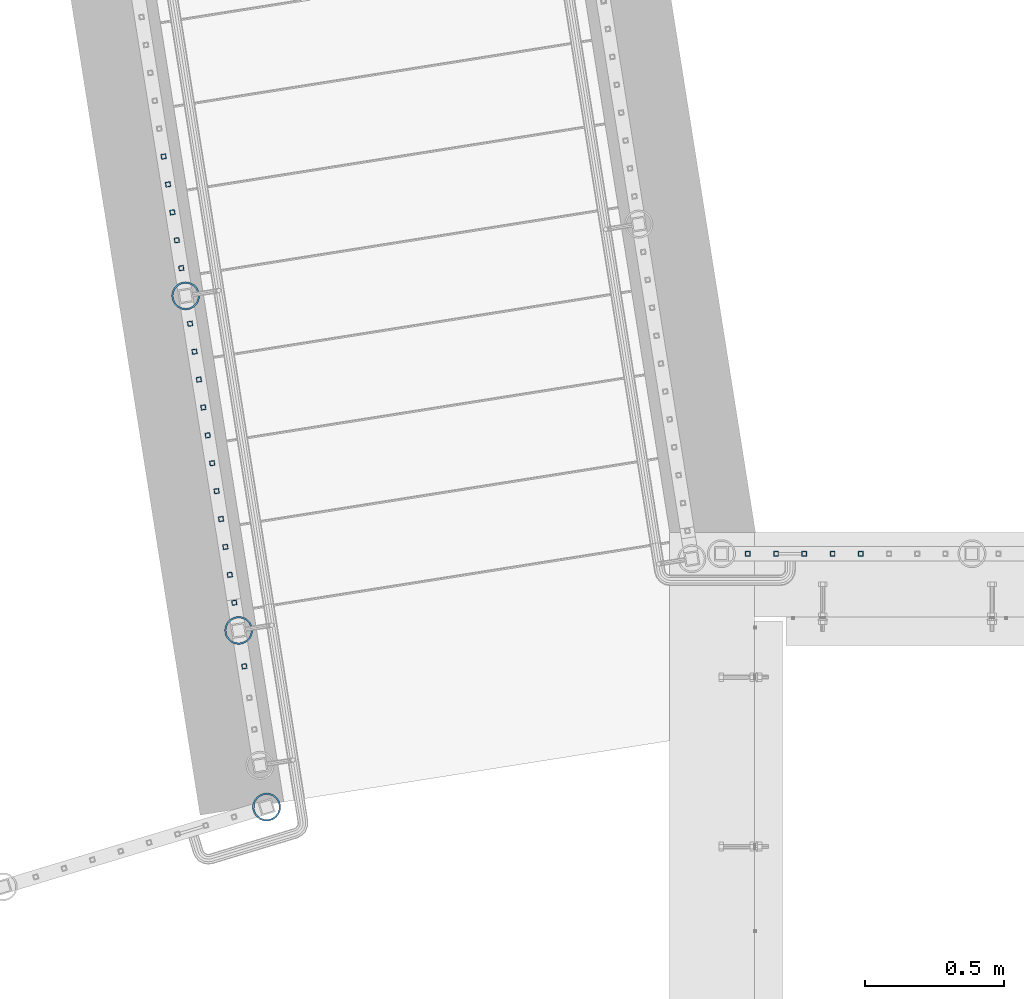
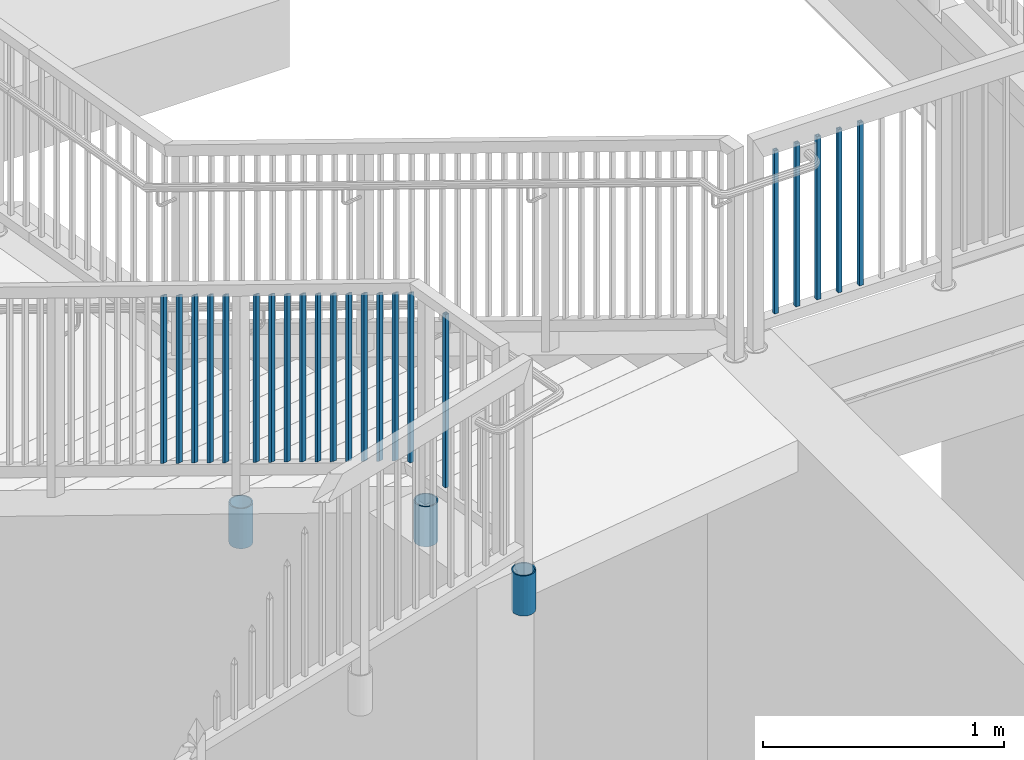
# One storey, part 210 of 975: 25 columns.
"""IFC2X3 building model written with IfcOpenShell, lengths in millimetres."""

from ifc_helpers import new_model, si_unit, frame, origin_with_axes, place, context, subcontext, project, spatial, faceted_brep, material, type_object, element, save


model = new_model("IFC2X3")

# Units and contexts
model_context = context("Model", 3, precision=1e-05, world=origin_with_axes())
body_context = subcontext(model_context, "Body", "Model", "MODEL_VIEW")
ifc_project = project(units=[si_unit("LENGTHUNIT", "METRE", prefix="MILLI"), si_unit("AREAUNIT", "SQUARE_METRE"), si_unit("VOLUMEUNIT", "CUBIC_METRE"), si_unit("MASSUNIT", "GRAM", prefix="KILO"), si_unit("TIMEUNIT", "SECOND"), si_unit("PLANEANGLEUNIT", "RADIAN"), si_unit("SOLIDANGLEUNIT", "STERADIAN"), si_unit("THERMODYNAMICTEMPERATUREUNIT", "DEGREE_CELSIUS"), si_unit("LUMINOUSINTENSITYUNIT", "LUMEN")], contexts=[model_context])

# Site, building, storey
site_placement = place(None, origin_with_axes())
site = spatial("IfcSite", under=ifc_project, at=site_placement, CompositionType="ELEMENT")
building_placement = place(site_placement, origin_with_axes())
building = spatial("IfcBuilding", under=site, at=building_placement, Name="Undefined", CompositionType="ELEMENT")
storey_placement = place(building_placement, origin_with_axes())
storey = spatial("IfcBuildingStorey", under=building, at=storey_placement, Name="Undefined", CompositionType="ELEMENT", Elevation=0.0)

# Columns
ifc_material_1 = material()
column_type_1 = type_object("IfcColumnType", Name="HSS3/4X3/4X.120_TUBES", PredefinedType="NOTDEFINED")
for number, where, z_axis, x_axis, name in (
    (1, (-1757.47829396319, 21700.2296265372, 3511.41761990565), (-0.987688340611262, -0.156434464938429, 0.0), (0.0, 0.0, 1.0), "PICKET"),
    (2, (-1773.38117438056, 21800.6345854193, 3455.29472263607), (-0.987688340611262, -0.156434464938429, 0.0), (0.0, 0.0, 1.0), "PICKET"),
    (3, (-1789.28405479828, 21901.0395443037, 3399.17182536649), (-0.987688340611262, -0.156434464938429, 0.0), (0.0, 0.0, 1.0), "PICKET"),
    (4, (-1805.18693521926, 22001.4445032087, 3343.04892808418), (-0.987688340611262, -0.156434464938429, 0.0), (0.0, 0.0, 1.0), "PICKET"),
):
    element("IfcColumn", number, at=place(storey_placement, frame(where, z_axis=z_axis, x_axis=x_axis)), inside=storey, type_object=column_type_1, material=ifc_material_1, Name=name, ObjectType="HSS3/4X3/4X.120_TUBES", context=body_context, shape_type="Brep", body=[
        faceted_brep([(-3.50571911954194, 6.34999999999491, -6.34999999999809), (3.50573940444565, -6.34999999999491, -6.34999999999991), (852.681084613786, -6.34999999999491, -6.34999999999991), (845.669626084644, 6.34999999999491, -6.34999999999809), (3.50571915819046, -6.34999999998763, 6.34999999999786), (852.681084601087, -6.34999999998763, 6.34999999999786), (-3.50573936579713, 6.34999999999854, 6.34999999999968), (845.669626071945, 6.34999999999854, 6.34999999999968), (-5.25857868897492, 9.5249999999869, -9.52499999999668), (-5.25860905835771, 9.52500000000146, 9.52499999999964), (843.916761436485, 9.52500000000146, 9.52499999999964), (843.916761455533, 9.5249999999869, -9.52499999999668), (5.25857872762344, -9.52499999998327, 9.52499999999645), (854.433949230198, -9.52499999998327, 9.52499999999645), (5.25860909700623, -9.52499999999418, -9.52499999999986), (854.433949249247, -9.52499999999418, -9.52499999999986)], [[[0, 1, 2, 3]], [[1, 4, 5, 2]], [[4, 6, 7, 5]], [[6, 0, 3, 7]], [[8, 9, 10, 11]], [[9, 12, 13, 10]], [[12, 14, 15, 13]], [[14, 8, 11, 15]], [[13, 15, 11, 10], [5, 7, 3, 2]], [[14, 12, 9, 8], [6, 4, 1, 0]]]),
    ])
column_1_placement = place(storey_placement, frame((-1530.49996596622, 20267.1374371803, 4178.29999167089), z_axis=(-0.987688340611262, -0.156434464938429, 0.0), x_axis=(0.0, 0.0, 1.0)))
element("IfcColumn", 5, at=column_1_placement, inside=storey, type_object=column_type_1, material=ifc_material_1, Name="PICKET", ObjectType="HSS3/4X3/4X.120_TUBES", context=body_context, shape_type="Brep", body=[
    faceted_brep([(0.0, 6.34999999998763, -6.34999999998763), (0.0, -6.35000000000582, -6.34999999998763), (876.3, -6.35000000000218, -6.3500000000131), (876.3, 6.34999999999854, -6.35000000000946), (0.0, -6.34999999998763, 6.34999999998763), (876.3, -6.34999999999854, 6.34999999999127), (0.0, 6.35000000000946, 6.34999999998763), (876.3, 6.35000000000582, 6.34999999999491), (0.0, 9.52499999997963, -9.52499999997963), (0.0, 9.52500000000873, 9.5249999999869), (876.3, 9.52500000000146, 9.52499999999418), (876.3, 9.52499999999782, -9.52500000001237), (0.0, -9.52499999997963, 9.52499999998327), (876.3, -9.52499999999782, 9.52499999999054), (0.0, -9.52500000000873, -9.5249999999869), (876.3, -9.52500000000146, -9.52500000001237)], [[[0, 1, 2, 3]], [[1, 4, 5, 2]], [[4, 6, 7, 5]], [[6, 0, 3, 7]], [[8, 9, 10, 11]], [[9, 12, 13, 10]], [[12, 14, 15, 13]], [[14, 8, 11, 15]], [[13, 15, 11, 10], [5, 7, 3, 2]], [[14, 12, 9, 8], [6, 4, 1, 0]]]),
])
for number, where, z_axis, x_axis, name in (
    (6, (281.646988509125, 20672.3889447702, 4178.3000105335), (1.0, 0.0, 0.0), (0.0, 0.0, 1.0), "PICKET"),
    (7, (688.046988509125, 20672.3889447702, 4178.3000105335), (1.0, 0.0, 0.0), (0.0, 0.0, 1.0), "PICKET"),
    (8, (586.446988509125, 20672.3889447702, 4178.3000105335), (1.0, 0.0, 0.0), (0.0, 0.0, 1.0), "PICKET"),
    (9, (484.846988509125, 20672.3889447702, 4178.3000105335), (1.0, 0.0, 0.0), (0.0, 0.0, 1.0), "PICKET"),
    (10, (383.246988509125, 20672.3889447702, 4178.3000105335), (1.0, 0.0, 0.0), (0.0, 0.0, 1.0), "PICKET"),
):
    element("IfcColumn", number, at=place(storey_placement, frame(where, z_axis=z_axis, x_axis=x_axis)), inside=storey, type_object=column_type_1, material=ifc_material_1, Name=name, ObjectType="HSS3/4X3/4X.120_TUBES", context=body_context, shape_type="Brep", body=[
        faceted_brep([(0.0, 6.34999999998763, -6.34999999998763), (0.0, -6.35000000000582, -6.34999999998763), (825.49997943247, -6.35000000000582, -6.34999999998763), (825.49997943247, 6.34999999998763, -6.34999999998763), (0.0, -6.34999999998763, 6.34999999998763), (825.49997943247, -6.34999999998763, 6.34999999998763), (0.0, 6.35000000000946, 6.34999999998763), (825.49997943247, 6.35000000000946, 6.34999999998763), (0.0, 9.52499999997963, -9.52499999997963), (0.0, 9.52500000000873, 9.5249999999869), (825.49997943247, 9.52500000000873, 9.5249999999869), (825.49997943247, 9.52499999997963, -9.52499999997963), (0.0, -9.52499999997963, 9.52499999998327), (825.49997943247, -9.52499999997963, 9.52499999998327), (0.0, -9.52500000000873, -9.5249999999869), (825.49997943247, -9.52500000000873, -9.5249999999869)], [[[0, 1, 2, 3]], [[1, 4, 5, 2]], [[4, 6, 7, 5]], [[6, 0, 3, 7]], [[8, 9, 10, 11]], [[9, 12, 13, 10]], [[12, 14, 15, 13]], [[14, 8, 11, 15]], [[13, 15, 11, 10], [5, 7, 3, 2]], [[14, 12, 9, 8], [6, 4, 1, 0]]]),
    ])
column_2_placement = place(storey_placement, frame((-1566.75455173563, 20496.0398183421, 4178.2999918998), z_axis=(-0.987688340611262, -0.156434464938429, 0.0), x_axis=(0.0, 0.0, 1.0)))
element("IfcColumn", 11, at=column_2_placement, inside=storey, type_object=column_type_1, material=ifc_material_1, Name="PICKET", ObjectType="HSS3/4X3/4X.120_TUBES", context=body_context, shape_type="Brep", body=[
    faceted_brep([(0.0, 6.34999999998763, -6.34999999998763), (0.0, -6.35000000000582, -6.34999999998763), (858.898731993615, -6.34999999999491, -6.35000000000082), (851.887273465725, 6.34999999999491, -6.349999999999), (0.0, -6.34999999998763, 6.34999999998763), (858.898732006316, -6.34999999999127, 6.34999999999809), (0.0, 6.35000000000946, 6.34999999998763), (851.887273478426, 6.34999999999854, 6.34999999999991), (0.0, 9.52499999997963, -9.52499999997963), (0.0, 9.52500000000873, 9.5249999999869), (850.134408849629, 9.52499999999782, 9.52499999999964), (850.134408830578, 9.5249999999869, -9.52499999999827), (0.0, -9.52499999997963, 9.52499999998327), (860.651596641464, -9.52499999998327, 9.52499999999782), (0.0, -9.52500000000873, -9.5249999999869), (860.651596622412, -9.52499999999782, -9.52500000000055)], [[[0, 1, 2, 3]], [[1, 4, 5, 2]], [[4, 6, 7, 5]], [[6, 0, 3, 7]], [[8, 9, 10, 11]], [[9, 12, 13, 10]], [[12, 14, 15, 13]], [[14, 8, 11, 15]], [[13, 15, 11, 10], [5, 7, 3, 2]], [[14, 12, 9, 8], [6, 4, 1, 0]]]),
])
for number, where, z_axis, x_axis, name in (
    (12, (-1582.65714236297, 20596.444823131, 4142.88071913312), (-0.987688340611262, -0.156434464938429, 0.0), (0.0, 0.0, 1.0), "PICKET"),
    (13, (-1598.55973298952, 20696.8498279149, 4086.7578218725), (-0.987688340611262, -0.156434464938429, 0.0), (0.0, 0.0, 1.0), "PICKET"),
    (14, (-1614.46232361607, 20797.2548326989, 4030.63492461188), (-0.987688340611262, -0.156434464938429, 0.0), (0.0, 0.0, 1.0), "PICKET"),
    (15, (-1630.36491424261, 20897.6598374828, 3974.51202735126), (-0.987688340611262, -0.156434464938429, 0.0), (0.0, 0.0, 1.0), "PICKET"),
    (16, (-1646.26750486916, 20998.0648422667, 3918.38913009064), (-0.987688340611262, -0.156434464938429, 0.0), (0.0, 0.0, 1.0), "PICKET"),
    (17, (-1662.17009549584, 21098.4698470515, 3862.26623283002), (-0.987688340611262, -0.156434464938429, 0.0), (0.0, 0.0, 1.0), "PICKET"),
    (18, (-1678.07268612239, 21198.8748518354, 3806.1433355694), (-0.987688340611262, -0.156434464938429, 0.0), (0.0, 0.0, 1.0), "PICKET"),
    (19, (-1693.97527674894, 21299.2798566193, 3750.02043830879), (-0.987688340611262, -0.156434464938429, 0.0), (0.0, 0.0, 1.0), "PICKET"),
    (20, (-1709.87786737549, 21399.6848614032, 3693.89754104817), (-0.987688340611262, -0.156434464938429, 0.0), (0.0, 0.0, 1.0), "PICKET"),
    (21, (-1725.78045800204, 21500.0898661871, 3637.77464378755), (-0.987688340611262, -0.156434464938429, 0.0), (0.0, 0.0, 1.0), "PICKET"),
):
    element("IfcColumn", number, at=place(storey_placement, frame(where, z_axis=z_axis, x_axis=x_axis)), inside=storey, type_object=column_type_1, material=ifc_material_1, Name=name, ObjectType="HSS3/4X3/4X.120_TUBES", context=body_context, shape_type="Brep", body=[
        faceted_brep([(-17.9916664943412, 6.34999999999491, -6.34999999999945), (-10.9802079664514, -6.34999999999127, -6.35000000000173), (838.195107257512, -6.34999999999491, -6.35000000000082), (831.183648729623, 6.34999999999491, -6.34999999999945), (-10.9802079664505, -6.34999999998763, 6.34999999999764), (838.195107270213, -6.34999999999127, 6.34999999999809), (-17.9916664943403, 6.35000000000218, 6.34999999999945), (831.183648742323, 6.35000000000218, 6.34999999999945), (-19.7445311263136, 9.52499999999054, -9.52499999999918), (-19.7445311263118, 9.52500000000146, 9.52499999999918), (829.430784113527, 9.52499999999782, 9.52499999999964), (829.430784094476, 9.52499999999054, -9.52499999999827), (-9.22734333447806, -9.52499999998327, 9.52499999999691), (839.947971905361, -9.5249999999869, 9.52499999999736), (-9.22734333447897, -9.52499999999418, -9.525000000001), (839.947971886309, -9.52499999999782, -9.525000000001)], [[[0, 1, 2, 3]], [[1, 4, 5, 2]], [[4, 6, 7, 5]], [[6, 0, 3, 7]], [[8, 9, 10, 11]], [[9, 12, 13, 10]], [[12, 14, 15, 13]], [[14, 8, 11, 15]], [[13, 15, 11, 10], [5, 7, 3, 2]], [[14, 12, 9, 8], [6, 4, 1, 0]]]),
    ])
column_3_placement = place(storey_placement, frame((-1821.08981563266, 22101.8494620658, 3286.92607132801), z_axis=(-0.987688340611262, -0.156434464938429, 0.0), x_axis=(0.0, 0.0, 1.0)))
element("IfcColumn", 22, at=column_3_placement, inside=storey, type_object=column_type_1, material=ifc_material_1, Name="PICKET", ObjectType="HSS3/4X3/4X.120_TUBES", context=body_context, shape_type="Brep", body=[
    faceted_brep([(-3.50571911954194, 6.34999999999491, -6.34999999999809), (3.50573940444565, -6.34999999999491, -6.34999999999991), (852.681084613786, -6.34999999999491, -6.34999999999991), (845.669626084644, 6.34999999999491, -6.34999999999809), (3.50571915819046, -6.34999999998763, 6.34999999999786), (852.681084601087, -6.34999999998763, 6.34999999999786), (-3.50573936579713, 6.34999999999854, 6.34999999999968), (845.669626071945, 6.34999999999854, 6.34999999999968), (-5.25857868897492, 9.5249999999869, -9.52499999999668), (-5.25860905835771, 9.52500000000146, 9.52499999999964), (843.916761436485, 9.52500000000146, 9.52499999999964), (843.916761455533, 9.5249999999869, -9.52499999999668), (5.25857872762344, -9.52499999998327, 9.52499999999645), (854.433949230198, -9.52499999998327, 9.52499999999645), (5.25860909700623, -9.52499999999418, -9.52499999999986), (854.433949249247, -9.52499999999418, -9.52499999999986)], [[[0, 1, 2, 3]], [[1, 4, 5, 2]], [[4, 6, 7, 5]], [[6, 0, 3, 7]], [[8, 9, 10, 11]], [[9, 12, 13, 10]], [[12, 14, 15, 13]], [[14, 8, 11, 15]], [[13, 15, 11, 10], [5, 7, 3, 2]], [[14, 12, 9, 8], [6, 4, 1, 0]]]),
])
ifc_material_2 = material(Name="STEEL/A53")
column_type_2 = type_object("IfcColumnType", Name="PIPE3-1/2STD", PredefinedType="NOTDEFINED")
column_4_placement = place(storey_placement, frame((-1450.2685998797, 19760.5767186958, 3835.40001060704), z_axis=(-0.881600346999202, 0.471996639999572, -8.71836346050259e-09), x_axis=(0.0, 0.0, 1.0)))
element("IfcColumn", 23, at=column_4_placement, inside=storey, type_object=column_type_2, material=ifc_material_2, ObjectType="PIPE3-1/2STD", context=body_context, shape_type="Brep", body=[
    faceted_brep([(0.0, -45.0595999999932, 1.45519152283669e-11), (0.0, -42.8542262016344, 13.924182159768), (203.199999999991, -42.8542262017145, 13.9241821598171), (203.19999999999, -45.0596000000478, 5.82076609134674e-11), (0.0, -36.45398215971, 26.4853683542424), (203.199999999993, -36.45398215981, 26.4853683542988), (0.0, -26.4853683541623, 36.45398215979), (203.199999999995, -26.4853683542788, 36.4539821598537), (0.0, -13.9241821596988, 42.8542262017108), (203.199999999998, -13.9241821598262, 42.8542262017836), (0.0, 3.63797880709171e-11, 45.0596000000514), (203.2, -9.27684595808387e-11, 45.0596000001387), (0.0, 13.9241821597716, 42.8542262017036), (203.200000000003, 13.9241821596443, 42.8542262017927), (0.0, 26.4853683542242, 36.4539821597718), (203.200000000006, 26.4853683541096, 36.4539821598701), (0.0, 36.4539821597537, 26.4853683542206), (203.200000000008, 36.4539821596554, 26.4853683543224), (0.0, 42.8542262016563, 13.9241821597425), (203.200000000009, 42.8542262015817, 13.9241821598443), (0.0, 45.0595999999932, -1.09139364212751e-11), (203.200000000009, 45.0595999999423, 8.9130480773747e-11), (0.0, 42.8542262016344, -13.9241821597643), (203.200000000008, 42.854226201609, -13.9241821596697), (0.0, 36.45398215971, -26.4853683542387), (203.200000000007, 36.4539821597045, -26.4853683541514), (0.0, 26.4853683541623, -36.4539821597864), (203.200000000004, 26.4853683541733, -36.4539821597064), (0.0, 13.9241821596988, -42.8542262017072), (203.200000000002, 13.9241821597225, -42.8542262016381), (0.0, -3.63797880709171e-11, -45.0596000000478), (203.199999999999, -9.09494701772928e-12, -45.0595999999914), (0.0, -13.9241821597716, -42.8542262016963), (203.199999999996, -13.9241821597479, -42.8542262016472), (0.0, -26.4853683542242, -36.4539821597682), (203.199999999993, -26.4853683542133, -36.4539821597227), (0.0, -36.4539821597537, -26.4853683542169), (203.199999999992, -36.4539821597609, -26.4853683541751), (0.0, -42.8542262016563, -13.9241821597352), (203.199999999991, -42.8542262016872, -13.924182159697), (0.0, -50.799999999992, 1.81898940354586e-11), (0.0, -48.3136710278013, -15.6980633142484), (203.199999999989, -48.313671027825, -15.6980633142139), (203.199999999989, -50.8000000000466, 5.63886715099216e-11), (0.0, -41.0980633142644, -29.8594908164741), (203.19999999999, -41.0980633142663, -29.8594908164414), (0.0, -29.859490816485, -41.0980633142826), (203.199999999993, -29.8594908164687, -41.0980633142426), (0.0, -15.6980633142848, -48.313671027845), (203.199999999995, -15.6980633142539, -48.313671027794), (0.0, -4.36557456851006e-11, -50.8000000000575), (203.199999999998, -7.27595761418343e-12, -50.7999999999993), (0.0, 15.6980633142011, -48.3136710278523), (203.200000000002, 15.6980633142375, -48.3136710277831), (0.0, 29.8594908164159, -41.0980633143045), (203.200000000005, 29.8594908164378, -41.0980633142226), (0.0, 41.0980633142135, -29.8594908165032), (203.200000000008, 41.0980633142171, -29.8594908164141), (0.0, 48.3136710277722, -15.6980633142775), (203.200000000009, 48.3136710277504, -15.6980633141811), (0.0, 50.799999999992, -1.45519152283669e-11), (203.20000000001, 50.7999999999411, 9.09494701772928e-11), (0.0, 48.313671027794, 15.6980633142521), (203.20000000001, 48.3136710277213, 15.6980633143594), (0.0, 41.0980633142644, 29.8594908164814), (203.200000000008, 41.0980633141626, 29.8594908165887), (0.0, 29.859490816485, 41.0980633142863), (203.200000000007, 29.8594908163632, 41.0980633143899), (0.0, 15.6980633142848, 48.3136710278486), (203.200000000004, 15.6980633141484, 48.3136710279414), (0.0, 4.00177668780088e-11, 50.8000000000611), (203.200000000001, -9.82254277914762e-11, 50.8000000001466), (0.0, -15.6980633142011, 48.3136710278559), (203.199999999997, -15.698063314343, 48.3136710279305), (0.0, -29.8594908164159, 41.0980633143081), (203.199999999994, -29.8594908165433, 41.0980633143681), (0.0, -41.0980633142171, 29.8594908165069), (203.199999999992, -41.0980633143226, 29.8594908165596), (0.0, -48.3136710277722, 15.6980633142812), (203.19999999999, -48.3136710278559, 15.6980633143285)], [[[0, 1, 2, 3]], [[1, 4, 5, 2]], [[4, 6, 7, 5]], [[6, 8, 9, 7]], [[8, 10, 11, 9]], [[10, 12, 13, 11]], [[12, 14, 15, 13]], [[14, 16, 17, 15]], [[16, 18, 19, 17]], [[18, 20, 21, 19]], [[20, 22, 23, 21]], [[22, 24, 25, 23]], [[24, 26, 27, 25]], [[26, 28, 29, 27]], [[28, 30, 31, 29]], [[30, 32, 33, 31]], [[32, 34, 35, 33]], [[34, 36, 37, 35]], [[36, 38, 39, 37]], [[38, 0, 3, 39]], [[40, 41, 42, 43]], [[41, 44, 45, 42]], [[44, 46, 47, 45]], [[46, 48, 49, 47]], [[48, 50, 51, 49]], [[50, 52, 53, 51]], [[52, 54, 55, 53]], [[54, 56, 57, 55]], [[56, 58, 59, 57]], [[58, 60, 61, 59]], [[60, 62, 63, 61]], [[62, 64, 65, 63]], [[64, 66, 67, 65]], [[66, 68, 69, 67]], [[68, 70, 71, 69]], [[70, 72, 73, 71]], [[72, 74, 75, 73]], [[74, 76, 77, 75]], [[76, 78, 79, 77]], [[78, 40, 43, 79]], [[45, 47, 49, 51, 53, 55, 57, 59, 61, 63, 65, 67, 69, 71, 73, 75, 77, 79, 43, 42], [5, 7, 9, 11, 13, 15, 17, 19, 21, 23, 25, 27, 29, 31, 33, 35, 37, 39, 3, 2]], [[78, 76, 74, 72, 70, 68, 66, 64, 62, 60, 58, 56, 54, 52, 50, 48, 46, 44, 41, 40], [38, 36, 34, 32, 30, 28, 26, 24, 22, 20, 18, 16, 14, 12, 10, 8, 6, 4, 1, 0]]]),
])
column_5_placement = place(storey_placement, frame((-1741.68303723399, 21600.4948662992, 3162.29993752722), z_axis=(-0.587785252279345, -0.809016994384486, -8.09014181868407e-10), x_axis=(0.0, 0.0, 1.0)))
element("IfcColumn", 24, at=column_5_placement, inside=storey, type_object=column_type_2, material=ifc_material_2, ObjectType="PIPE3-1/2STD", context=body_context, shape_type="Brep", body=[
    faceted_brep([(0.0, -45.0595999999932, 1.45519152283669e-11), (0.0, -42.8542262016344, 13.924182159768), (203.199999999991, -42.8542262017145, 13.9241821598171), (203.19999999999, -45.0596000000478, 5.82076609134674e-11), (0.0, -36.45398215971, 26.4853683542424), (203.199999999993, -36.45398215981, 26.4853683542988), (0.0, -26.4853683541623, 36.45398215979), (203.199999999995, -26.4853683542788, 36.4539821598537), (0.0, -13.9241821596988, 42.8542262017108), (203.199999999998, -13.9241821598262, 42.8542262017836), (0.0, 3.63797880709171e-11, 45.0596000000514), (203.2, -9.27684595808387e-11, 45.0596000001387), (0.0, 13.9241821597716, 42.8542262017036), (203.200000000003, 13.9241821596443, 42.8542262017927), (0.0, 26.4853683542242, 36.4539821597718), (203.200000000006, 26.4853683541096, 36.4539821598701), (0.0, 36.4539821597537, 26.4853683542206), (203.200000000008, 36.4539821596554, 26.4853683543224), (0.0, 42.8542262016563, 13.9241821597425), (203.200000000009, 42.8542262015817, 13.9241821598443), (0.0, 45.0595999999932, -1.09139364212751e-11), (203.200000000009, 45.0595999999423, 8.9130480773747e-11), (0.0, 42.8542262016344, -13.9241821597643), (203.200000000008, 42.854226201609, -13.9241821596697), (0.0, 36.45398215971, -26.4853683542387), (203.200000000007, 36.4539821597045, -26.4853683541514), (0.0, 26.4853683541623, -36.4539821597864), (203.200000000004, 26.4853683541733, -36.4539821597064), (0.0, 13.9241821596988, -42.8542262017072), (203.200000000002, 13.9241821597225, -42.8542262016381), (0.0, -3.63797880709171e-11, -45.0596000000478), (203.199999999999, -9.09494701772928e-12, -45.0595999999914), (0.0, -13.9241821597716, -42.8542262016963), (203.199999999996, -13.9241821597479, -42.8542262016472), (0.0, -26.4853683542242, -36.4539821597682), (203.199999999993, -26.4853683542133, -36.4539821597227), (0.0, -36.4539821597537, -26.4853683542169), (203.199999999992, -36.4539821597609, -26.4853683541751), (0.0, -42.8542262016563, -13.9241821597352), (203.199999999991, -42.8542262016872, -13.924182159697), (0.0, -50.799999999992, 1.81898940354586e-11), (0.0, -48.3136710278013, -15.6980633142484), (203.199999999989, -48.313671027825, -15.6980633142139), (203.199999999989, -50.8000000000466, 5.63886715099216e-11), (0.0, -41.0980633142644, -29.8594908164741), (203.19999999999, -41.0980633142663, -29.8594908164414), (0.0, -29.859490816485, -41.0980633142826), (203.199999999993, -29.8594908164687, -41.0980633142426), (0.0, -15.6980633142848, -48.313671027845), (203.199999999995, -15.6980633142539, -48.313671027794), (0.0, -4.36557456851006e-11, -50.8000000000575), (203.199999999998, -7.27595761418343e-12, -50.7999999999993), (0.0, 15.6980633142011, -48.3136710278523), (203.200000000002, 15.6980633142375, -48.3136710277831), (0.0, 29.8594908164159, -41.0980633143045), (203.200000000005, 29.8594908164378, -41.0980633142226), (0.0, 41.0980633142135, -29.8594908165032), (203.200000000008, 41.0980633142171, -29.8594908164141), (0.0, 48.3136710277722, -15.6980633142775), (203.200000000009, 48.3136710277504, -15.6980633141811), (0.0, 50.799999999992, -1.45519152283669e-11), (203.20000000001, 50.7999999999411, 9.09494701772928e-11), (0.0, 48.313671027794, 15.6980633142521), (203.20000000001, 48.3136710277213, 15.6980633143594), (0.0, 41.0980633142644, 29.8594908164814), (203.200000000008, 41.0980633141626, 29.8594908165887), (0.0, 29.859490816485, 41.0980633142863), (203.200000000007, 29.8594908163632, 41.0980633143899), (0.0, 15.6980633142848, 48.3136710278486), (203.200000000004, 15.6980633141484, 48.3136710279414), (0.0, 4.00177668780088e-11, 50.8000000000611), (203.200000000001, -9.82254277914762e-11, 50.8000000001466), (0.0, -15.6980633142011, 48.3136710278559), (203.199999999997, -15.698063314343, 48.3136710279305), (0.0, -29.8594908164159, 41.0980633143081), (203.199999999994, -29.8594908165433, 41.0980633143681), (0.0, -41.0980633142171, 29.8594908165069), (203.199999999992, -41.0980633143226, 29.8594908165596), (0.0, -48.3136710277722, 15.6980633142812), (203.19999999999, -48.3136710278559, 15.6980633143285)], [[[0, 1, 2, 3]], [[1, 4, 5, 2]], [[4, 6, 7, 5]], [[6, 8, 9, 7]], [[8, 10, 11, 9]], [[10, 12, 13, 11]], [[12, 14, 15, 13]], [[14, 16, 17, 15]], [[16, 18, 19, 17]], [[18, 20, 21, 19]], [[20, 22, 23, 21]], [[22, 24, 25, 23]], [[24, 26, 27, 25]], [[26, 28, 29, 27]], [[28, 30, 31, 29]], [[30, 32, 33, 31]], [[32, 34, 35, 33]], [[34, 36, 37, 35]], [[36, 38, 39, 37]], [[38, 0, 3, 39]], [[40, 41, 42, 43]], [[41, 44, 45, 42]], [[44, 46, 47, 45]], [[46, 48, 49, 47]], [[48, 50, 51, 49]], [[50, 52, 53, 51]], [[52, 54, 55, 53]], [[54, 56, 57, 55]], [[56, 58, 59, 57]], [[58, 60, 61, 59]], [[60, 62, 63, 61]], [[62, 64, 65, 63]], [[64, 66, 67, 65]], [[66, 68, 69, 67]], [[68, 70, 71, 69]], [[70, 72, 73, 71]], [[72, 74, 75, 73]], [[74, 76, 77, 75]], [[76, 78, 79, 77]], [[78, 40, 43, 79]], [[45, 47, 49, 51, 53, 55, 57, 59, 61, 63, 65, 67, 69, 71, 73, 75, 77, 79, 43, 42], [5, 7, 9, 11, 13, 15, 17, 19, 21, 23, 25, 27, 29, 31, 33, 35, 37, 39, 3, 2]], [[78, 76, 74, 72, 70, 68, 66, 64, 62, 60, 58, 56, 54, 52, 50, 48, 46, 44, 41, 40], [38, 36, 34, 32, 30, 28, 26, 24, 22, 20, 18, 16, 14, 12, 10, 8, 6, 4, 1, 0]]]),
])
column_6_placement = place(storey_placement, frame((-1550.95813857823, 20396.3052477243, 3835.40003518347), z_axis=(-0.587785252279345, -0.809016994384486, -8.09014181868407e-10), x_axis=(0.0, 0.0, 1.0)))
element("IfcColumn", 25, at=column_6_placement, inside=storey, type_object=column_type_2, material=ifc_material_2, ObjectType="PIPE3-1/2STD", context=body_context, shape_type="Brep", body=[
    faceted_brep([(0.0, -45.0595999999932, 1.45519152283669e-11), (0.0, -42.8542262016344, 13.924182159768), (203.199999999991, -42.8542262017145, 13.9241821598171), (203.19999999999, -45.0596000000478, 5.82076609134674e-11), (0.0, -36.45398215971, 26.4853683542424), (203.199999999993, -36.45398215981, 26.4853683542988), (0.0, -26.4853683541623, 36.45398215979), (203.199999999995, -26.4853683542788, 36.4539821598537), (0.0, -13.9241821596988, 42.8542262017108), (203.199999999998, -13.9241821598262, 42.8542262017836), (0.0, 3.63797880709171e-11, 45.0596000000514), (203.2, -9.27684595808387e-11, 45.0596000001387), (0.0, 13.9241821597716, 42.8542262017036), (203.200000000003, 13.9241821596443, 42.8542262017927), (0.0, 26.4853683542242, 36.4539821597718), (203.200000000006, 26.4853683541096, 36.4539821598701), (0.0, 36.4539821597537, 26.4853683542206), (203.200000000008, 36.4539821596554, 26.4853683543224), (0.0, 42.8542262016563, 13.9241821597425), (203.200000000009, 42.8542262015817, 13.9241821598443), (0.0, 45.0595999999932, -1.09139364212751e-11), (203.200000000009, 45.0595999999423, 8.9130480773747e-11), (0.0, 42.8542262016344, -13.9241821597643), (203.200000000008, 42.854226201609, -13.9241821596697), (0.0, 36.45398215971, -26.4853683542387), (203.200000000007, 36.4539821597045, -26.4853683541514), (0.0, 26.4853683541623, -36.4539821597864), (203.200000000004, 26.4853683541733, -36.4539821597064), (0.0, 13.9241821596988, -42.8542262017072), (203.200000000002, 13.9241821597225, -42.8542262016381), (0.0, -3.63797880709171e-11, -45.0596000000478), (203.199999999999, -9.09494701772928e-12, -45.0595999999914), (0.0, -13.9241821597716, -42.8542262016963), (203.199999999996, -13.9241821597479, -42.8542262016472), (0.0, -26.4853683542242, -36.4539821597682), (203.199999999993, -26.4853683542133, -36.4539821597227), (0.0, -36.4539821597537, -26.4853683542169), (203.199999999992, -36.4539821597609, -26.4853683541751), (0.0, -42.8542262016563, -13.9241821597352), (203.199999999991, -42.8542262016872, -13.924182159697), (0.0, -50.799999999992, 1.81898940354586e-11), (0.0, -48.3136710278013, -15.6980633142484), (203.199999999989, -48.313671027825, -15.6980633142139), (203.199999999989, -50.8000000000466, 5.63886715099216e-11), (0.0, -41.0980633142644, -29.8594908164741), (203.19999999999, -41.0980633142663, -29.8594908164414), (0.0, -29.859490816485, -41.0980633142826), (203.199999999993, -29.8594908164687, -41.0980633142426), (0.0, -15.6980633142848, -48.313671027845), (203.199999999995, -15.6980633142539, -48.313671027794), (0.0, -4.36557456851006e-11, -50.8000000000575), (203.199999999998, -7.27595761418343e-12, -50.7999999999993), (0.0, 15.6980633142011, -48.3136710278523), (203.200000000002, 15.6980633142375, -48.3136710277831), (0.0, 29.8594908164159, -41.0980633143045), (203.200000000005, 29.8594908164378, -41.0980633142226), (0.0, 41.0980633142135, -29.8594908165032), (203.200000000008, 41.0980633142171, -29.8594908164141), (0.0, 48.3136710277722, -15.6980633142775), (203.200000000009, 48.3136710277504, -15.6980633141811), (0.0, 50.799999999992, -1.45519152283669e-11), (203.20000000001, 50.7999999999411, 9.09494701772928e-11), (0.0, 48.313671027794, 15.6980633142521), (203.20000000001, 48.3136710277213, 15.6980633143594), (0.0, 41.0980633142644, 29.8594908164814), (203.200000000008, 41.0980633141626, 29.8594908165887), (0.0, 29.859490816485, 41.0980633142863), (203.200000000007, 29.8594908163632, 41.0980633143899), (0.0, 15.6980633142848, 48.3136710278486), (203.200000000004, 15.6980633141484, 48.3136710279414), (0.0, 4.00177668780088e-11, 50.8000000000611), (203.200000000001, -9.82254277914762e-11, 50.8000000001466), (0.0, -15.6980633142011, 48.3136710278559), (203.199999999997, -15.698063314343, 48.3136710279305), (0.0, -29.8594908164159, 41.0980633143081), (203.199999999994, -29.8594908165433, 41.0980633143681), (0.0, -41.0980633142171, 29.8594908165069), (203.199999999992, -41.0980633143226, 29.8594908165596), (0.0, -48.3136710277722, 15.6980633142812), (203.19999999999, -48.3136710278559, 15.6980633143285)], [[[0, 1, 2, 3]], [[1, 4, 5, 2]], [[4, 6, 7, 5]], [[6, 8, 9, 7]], [[8, 10, 11, 9]], [[10, 12, 13, 11]], [[12, 14, 15, 13]], [[14, 16, 17, 15]], [[16, 18, 19, 17]], [[18, 20, 21, 19]], [[20, 22, 23, 21]], [[22, 24, 25, 23]], [[24, 26, 27, 25]], [[26, 28, 29, 27]], [[28, 30, 31, 29]], [[30, 32, 33, 31]], [[32, 34, 35, 33]], [[34, 36, 37, 35]], [[36, 38, 39, 37]], [[38, 0, 3, 39]], [[40, 41, 42, 43]], [[41, 44, 45, 42]], [[44, 46, 47, 45]], [[46, 48, 49, 47]], [[48, 50, 51, 49]], [[50, 52, 53, 51]], [[52, 54, 55, 53]], [[54, 56, 57, 55]], [[56, 58, 59, 57]], [[58, 60, 61, 59]], [[60, 62, 63, 61]], [[62, 64, 65, 63]], [[64, 66, 67, 65]], [[66, 68, 69, 67]], [[68, 70, 71, 69]], [[70, 72, 73, 71]], [[72, 74, 75, 73]], [[74, 76, 77, 75]], [[76, 78, 79, 77]], [[78, 40, 43, 79]], [[45, 47, 49, 51, 53, 55, 57, 59, 61, 63, 65, 67, 69, 71, 73, 75, 77, 79, 43, 42], [5, 7, 9, 11, 13, 15, 17, 19, 21, 23, 25, 27, 29, 31, 33, 35, 37, 39, 3, 2]], [[78, 76, 74, 72, 70, 68, 66, 64, 62, 60, 58, 56, 54, 52, 50, 48, 46, 44, 41, 40], [38, 36, 34, 32, 30, 28, 26, 24, 22, 20, 18, 16, 14, 12, 10, 8, 6, 4, 1, 0]]]),
])

save(model, "model.ifc")
